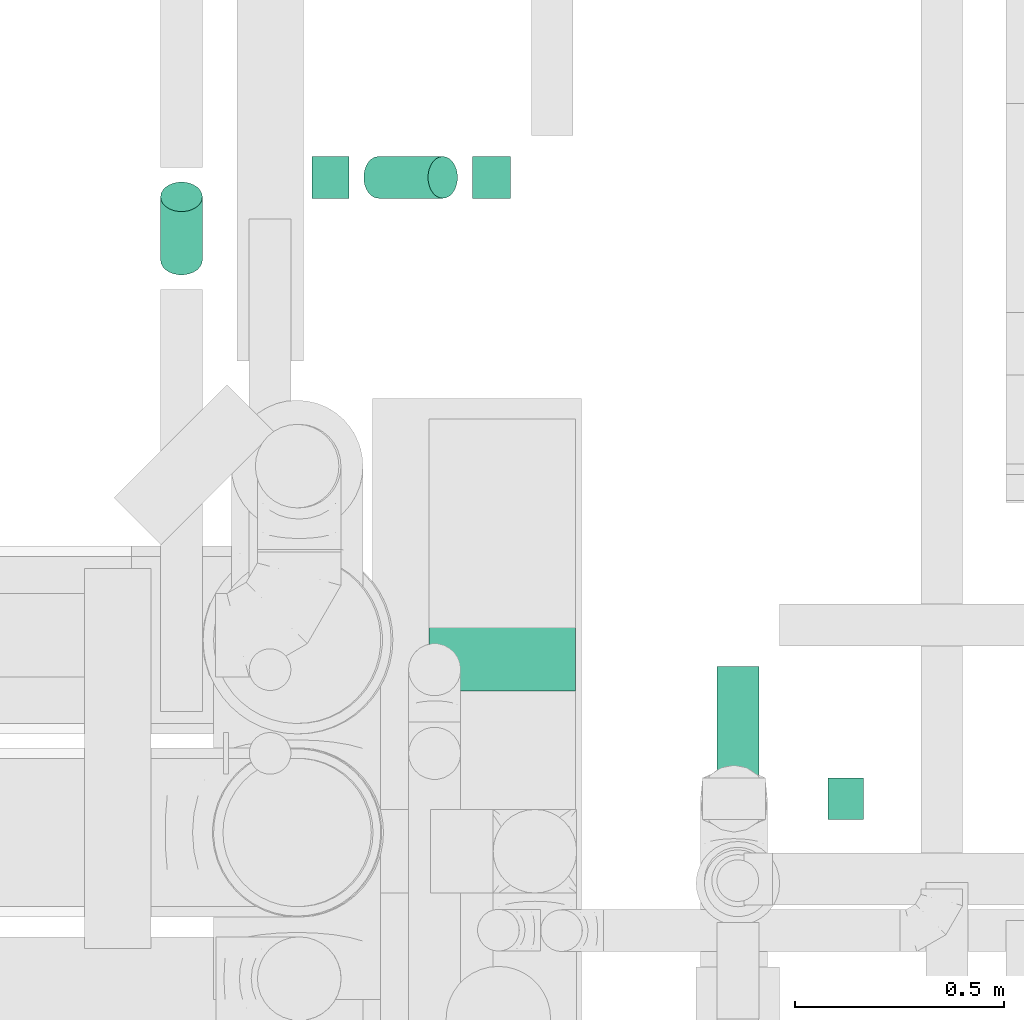
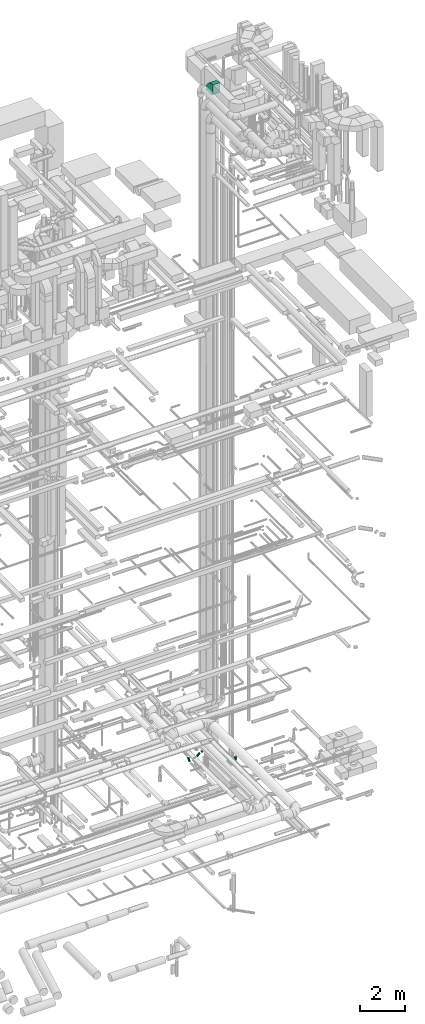
# One storey, part 271 of 337: 6 flow segments, 1 flow fitting.
"""IFC2X3 building model written with IfcOpenShell, lengths in millimetres."""

from ifc_helpers import new_model, entity, si_unit, converted_unit, derived_unit, direction, frame, frame_2d, origin, origin_2d_with_axis, place, context, subcontext, project, spatial, polyline, circle_curve, parameter, trimmed, segment, composite_curve, rectangle, circle, outline, extrude, source, transform, mapped, material, type_object, type_shapes, element, save


model = new_model("IFC2X3")

# Units and contexts
model_context = context("Model", 3, precision=0.01, world=origin(), true_north=direction((6.12303176911189e-17, 1.0)))
body_context = subcontext(model_context, "Body", "Model", "MODEL_VIEW")
ifc_project = project(units=[si_unit("LENGTHUNIT", "METRE", prefix="MILLI"), si_unit("AREAUNIT", "SQUARE_METRE"), si_unit("VOLUMEUNIT", "CUBIC_METRE"), converted_unit("PLANEANGLEUNIT", "DEGREE", entity("IfcRatioMeasure", 0.0174532925199433), si_unit("PLANEANGLEUNIT", "RADIAN"), dimensions=[0, 0, 0, 0, 0, 0, 0]), si_unit("MASSUNIT", "GRAM", prefix="KILO"), derived_unit("MASSDENSITYUNIT", [(si_unit("MASSUNIT", "GRAM", prefix="KILO"), 1), (si_unit("LENGTHUNIT", "METRE"), -3)]), derived_unit("MOMENTOFINERTIAUNIT", [(si_unit("LENGTHUNIT", "METRE"), 4)]), si_unit("TIMEUNIT", "SECOND"), si_unit("FREQUENCYUNIT", "HERTZ"), si_unit("THERMODYNAMICTEMPERATUREUNIT", "DEGREE_CELSIUS"), derived_unit("THERMALTRANSMITTANCEUNIT", [(si_unit("MASSUNIT", "GRAM", prefix="KILO"), 1), (si_unit("THERMODYNAMICTEMPERATUREUNIT", "KELVIN"), -1), (si_unit("TIMEUNIT", "SECOND"), -3)]), derived_unit("VOLUMETRICFLOWRATEUNIT", [(si_unit("LENGTHUNIT", "METRE"), 3), (si_unit("TIMEUNIT", "SECOND"), -1)]), derived_unit("MASSFLOWRATEUNIT", [(si_unit("MASSUNIT", "GRAM", prefix="KILO"), 1), (si_unit("TIMEUNIT", "SECOND"), -1)]), derived_unit("ROTATIONALFREQUENCYUNIT", [(si_unit("TIMEUNIT", "SECOND"), -1)]), si_unit("ELECTRICCURRENTUNIT", "AMPERE"), si_unit("ELECTRICVOLTAGEUNIT", "VOLT"), si_unit("POWERUNIT", "WATT"), si_unit("FORCEUNIT", "NEWTON", prefix="KILO"), si_unit("ILLUMINANCEUNIT", "LUX"), si_unit("LUMINOUSFLUXUNIT", "LUMEN"), si_unit("LUMINOUSINTENSITYUNIT", "CANDELA"), derived_unit("USERDEFINED", [(si_unit("MASSUNIT", "GRAM", prefix="KILO"), -1), (si_unit("LENGTHUNIT", "METRE"), -2), (si_unit("TIMEUNIT", "SECOND"), 3), (si_unit("LUMINOUSFLUXUNIT", "LUMEN"), 1)]), derived_unit("LINEARVELOCITYUNIT", [(si_unit("LENGTHUNIT", "METRE"), 1), (si_unit("TIMEUNIT", "SECOND"), -1)]), si_unit("PRESSUREUNIT", "PASCAL"), derived_unit("USERDEFINED", [(si_unit("LENGTHUNIT", "METRE"), -2), (si_unit("MASSUNIT", "GRAM", prefix="KILO"), 1), (si_unit("TIMEUNIT", "SECOND"), -2)]), derived_unit("LINEARFORCEUNIT", [(si_unit("MASSUNIT", "GRAM", prefix="KILO"), 1), (si_unit("LENGTHUNIT", "METRE"), 1), (si_unit("TIMEUNIT", "SECOND"), -2), (si_unit("LENGTHUNIT", "METRE"), -1)]), derived_unit("PLANARFORCEUNIT", [(si_unit("MASSUNIT", "GRAM", prefix="KILO"), 1), (si_unit("LENGTHUNIT", "METRE"), 1), (si_unit("TIMEUNIT", "SECOND"), -2), (si_unit("LENGTHUNIT", "METRE"), -2)])], contexts=[model_context])

# Site, building, storey
site_placement = place(None, origin())
site = spatial("IfcSite", under=ifc_project, at=site_placement, CompositionType="ELEMENT")
building_placement = place(site_placement, origin())
building = spatial("IfcBuilding", under=site, at=building_placement, CompositionType="ELEMENT")
storey_placement = place(building_placement, origin())
storey = spatial("IfcBuildingStorey", under=building, at=storey_placement, CompositionType="ELEMENT", Elevation=0.0)

# Flow segments
duct_segment_type_1 = type_object("IfcDuctSegmentType", PredefinedType="NOTDEFINED")
flow_segment_1_placement = place(storey_placement, frame((68829.23, 11820.03, -750.0)))
element("IfcFlowSegment", 1, at=flow_segment_1_placement, inside=storey, type_object=duct_segment_type_1, context=body_context, shape_type="SweptSolid", body=[
    extrude(rectangle(XDim=84.8741199999927, YDim=99.9999999999989, at=origin_2d_with_axis()), frame((42.44, 50.0, 0.0), z_axis=(0.0, 0.0, 1.0), x_axis=(-1.0, 0.0, 0.0)), (0.0, 0.0, 1.0), 150.0),
])
duct_segment_type_2 = type_object("IfcDuctSegmentType", PredefinedType="NOTDEFINED")
flow_segment_2_placement = place(storey_placement, frame((68562.03, 11773.78, -951.6)))
element("IfcFlowSegment", 2, at=flow_segment_2_placement, inside=storey, type_object=duct_segment_type_2, context=body_context, shape_type="SweptSolid", body=[
    extrude(circle(Radius=50.0, at=origin_2d_with_axis()), frame((51.6, 0.0, 51.6), z_axis=(0.0, 1.0, 0.0), x_axis=(1.0, 0.0, 0.0)), (0.0, 0.0, 1.0), 412.157907856173),
])
flow_segment_3_placement = place(storey_placement, frame((67230.68, 13121.76, -1117.66)))
element("IfcFlowSegment", 3, at=flow_segment_3_placement, inside=storey, type_object=duct_segment_type_2, context=body_context, shape_type="SweptSolid", body=[
    extrude(circle(Radius=50.0, at=origin_2d_with_axis()), frame((51.6, 36.95, 36.95), z_axis=(0.0, 0.707106781186545, 0.70710678118655), x_axis=(1.0, 0.0, 0.0)), (0.0, 0.0, 1.0), 214.142135623723),
])
flow_segment_4_placement = place(storey_placement, frame((67594.25, 13305.11, -1163.94)))
element("IfcFlowSegment", 4, at=flow_segment_4_placement, inside=storey, type_object=duct_segment_type_2, context=body_context, shape_type="SweptSolid", body=[
    extrude(circle(Radius=50.0, at=origin_2d_with_axis()), frame((0.0, 51.6, 51.6), z_axis=(1.0, 0.0, 0.0), x_axis=(0.0, -1.0, 0.0)), (0.0, 0.0, 1.0), 88.7689353293576),
])
flow_segment_5_placement = place(storey_placement, frame((67716.78, 13305.11, -1120.0)))
element("IfcFlowSegment", 5, at=flow_segment_5_placement, inside=storey, type_object=duct_segment_type_2, context=body_context, shape_type="SweptSolid", body=[
    extrude(circle(Radius=50.0, at=origin_2d_with_axis()), frame((36.95, 51.6, 36.95), z_axis=(0.707106781186567, 0.0, 0.707106781186528), x_axis=(0.0, -1.0, 0.0)), (0.0, 0.0, 1.0), 217.45535294211),
])
flow_segment_6_placement = place(storey_placement, frame((67978.21, 13305.11, -951.6)))
element("IfcFlowSegment", 6, at=flow_segment_6_placement, inside=storey, type_object=duct_segment_type_2, context=body_context, shape_type="SweptSolid", body=[
    extrude(circle(Radius=50.0, at=origin_2d_with_axis()), frame((0.0, 51.6, 51.6), z_axis=(1.0, 0.0, 0.0), x_axis=(0.0, -1.0, 0.0)), (0.0, 0.0, 1.0), 91.1117437626763),
])

# Flow fitting
ifc_material = material()
duct_fitting_type = type_object("IfcDuctFittingType", PredefinedType="NOTDEFINED", material=ifc_material)
shared_shape = source(origin(), body_context, "Body", "SweptSolid", [
    extrude(outline(composite_curve([segment(polyline([(-450.0, -200.0), (50.0, -200.0)]), True, "CONTINUOUS"), segment(trimmed(circle_curve(frame_2d((200.0, -200.0), x_axis=(0.0, 1.0)), 150.0), [parameter(0.0)], [parameter(90.0000000000001)], True, "PARAMETER"), False, "CONTINUOUS"), segment(polyline([(200.0, -50.0), (200.0, 450.0)]), True, "CONTINUOUS"), segment(trimmed(circle_curve(frame_2d((200.0, -200.0), x_axis=(0.0, 1.0)), 650.0), [parameter(0.0)], [parameter(90.0000000000001)], True, "PARAMETER"), True, "CONTINUOUS")], self_intersect=False)), frame((-200.0, 200.0, -175.0), z_axis=(0.0, 0.0, 1.0), x_axis=(-1.0, 0.0, 0.0)), (0.0, 0.0, 1.0), 350.0),
])
type_shapes(duct_fitting_type, [shared_shape])
flow_fitting_placement = place(storey_placement, frame((68049.87, 12528.05, 35530.0), z_axis=(-0.999999987129909, 0.0, 0.000160437471795364), x_axis=(0.0, 1.0, 0.0)))
element("IfcFlowFitting", 7, at=flow_fitting_placement, inside=storey, type_object=duct_fitting_type, material=ifc_material, context=body_context, shape_type="MappedRepresentation", body=[
    mapped(shared_shape, transform((0.0, 0.0, 0.0), scale=1.0)),
])

save(model, "model.ifc")
